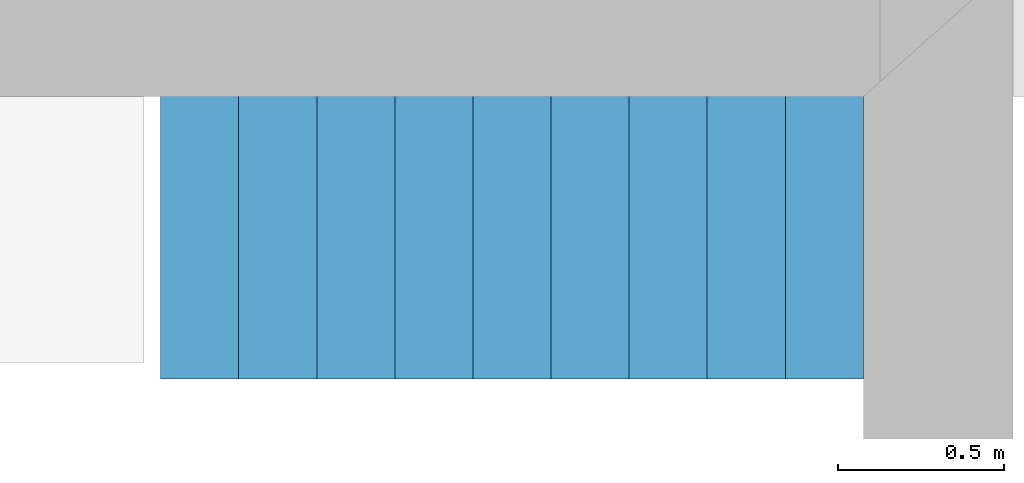
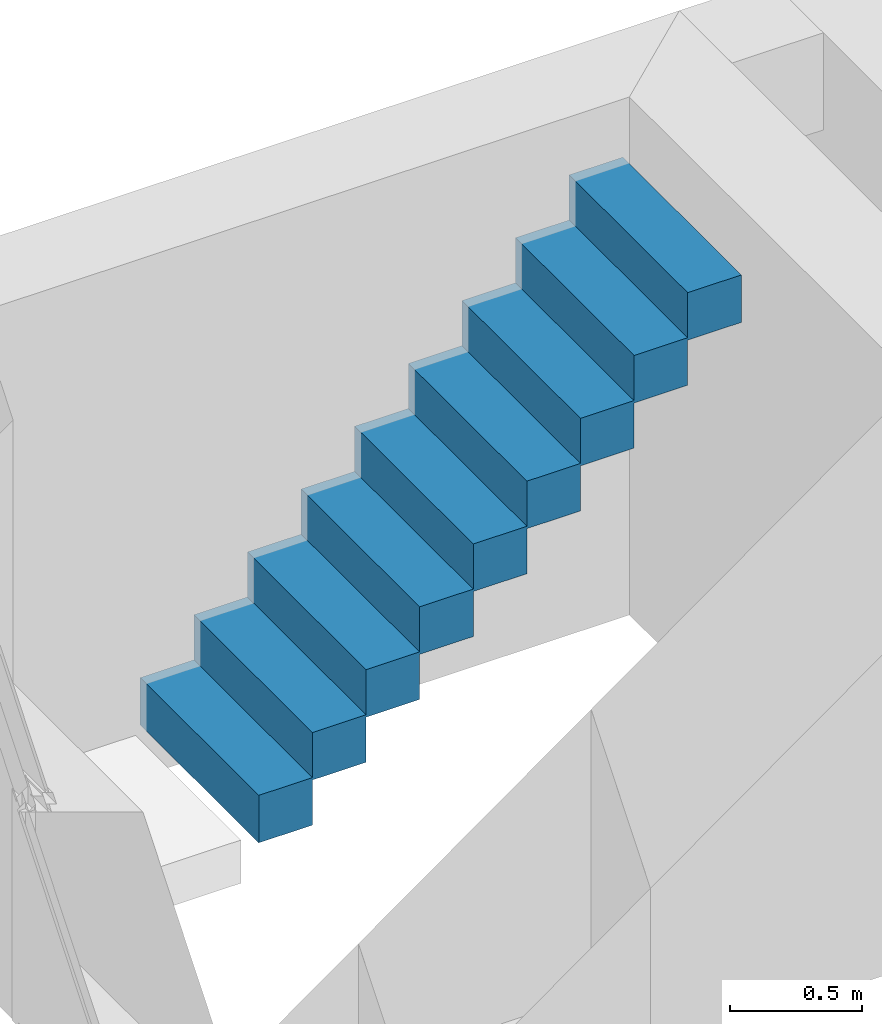
# One storey, part 3 of 3: 1 stair flight.
"""IFC4 building model written with IfcOpenShell, lengths in millimetres."""

from ifc_helpers import new_model, entity, si_unit, converted_unit, frame, origin_with_axes, origin_2d_with_axis, place, context, subcontext, project, spatial, polygons, source, transform, mapped, type_object, type_shapes, element, save


model = new_model("IFC4")

# Units and contexts
model_context = context("Model", 3, precision=1e-05, world=origin_with_axes())
plan_context = context("Plan", 2, precision=1e-05, world=origin_2d_with_axis())
body_context = subcontext(model_context, "Body", "Model", "MODEL_VIEW")
ifc_project = project(units=[si_unit("VOLUMEUNIT", "CUBIC_METRE"), si_unit("LENGTHUNIT", "METRE", prefix="MILLI"), converted_unit("PLANEANGLEUNIT", "degree", entity("IfcReal", 0.0174532925199433), si_unit("PLANEANGLEUNIT", "RADIAN"), dimensions=[0, 0, 0, 0, 0, 0, 0]), si_unit("AREAUNIT", "SQUARE_METRE")], contexts=[model_context, plan_context])

# Site, building, storey
site_placement = place(None, origin_with_axes())
site = spatial("IfcSite", under=ifc_project, at=site_placement)
building_placement = place(site_placement, origin_with_axes())
building = spatial("IfcBuilding", under=site, at=building_placement, Name="Building")
storey_placement = place(building_placement, frame((0.0, 0.0, -2400.00009536743), z_axis=(0.0, 0.0, 1.0), x_axis=(1.0, 0.0, 0.0)))
storey = spatial("IfcBuildingStorey", under=building, at=storey_placement, Name="Basement")

# Stair flight
stair_flight_type = type_object("IfcStairFlightType", Name="STF800", PredefinedType="STRAIGHT")
shared_shape = source(origin_with_axes(), body_context, "Body", "Tessellation", [
    polygons([(0.0, 0.0, -11.1111116409302), (234.999984741211, 0.0, -11.1111116409302), (234.999984741211, 0.0, 208.888900756836), (0.0, 0.0, 208.888900756836), (234.999984741211, 0.0, 197.777786254883), (469.999969482422, 0.0, 197.777786254883), (469.999969482422, 0.0, 417.777801513672), (234.999984741211, 0.0, 417.777801513672), (469.999969482422, 0.0, 406.666687011719), (704.999938964844, 0.0, 406.666687011719), (704.999938964844, 0.0, 626.666687011719), (469.999969482422, 0.0, 626.666687011719), (704.999938964844, 0.0, 615.555541992188), (939.999938964844, 0.0, 615.555541992188), (939.999938964844, 0.0, 835.555603027344), (704.999938964844, 0.0, 835.555603027344), (939.999938964844, 0.0, 824.444458007812), (1174.99987792969, 0.0, 824.444458007812), (1174.99987792969, 0.0, 1044.44445800781), (939.999938964844, 0.0, 1044.44445800781), (1174.99987792969, 0.0, 1033.33337402344), (1409.99987792969, 0.0, 1033.33337402344), (1409.99987792969, 0.0, 1253.33337402344), (1174.99987792969, 0.0, 1253.33337402344), (1409.99987792969, 0.0, 1242.22229003906), (1644.99987792969, 0.0, 1242.22229003906), (1644.99987792969, 0.0, 1462.22229003906), (1409.99987792969, 0.0, 1462.22229003906), (1644.99987792969, 0.0, 1451.11108398438), (1879.99987792969, 0.0, 1451.11108398438), (1879.99987792969, 0.0, 1671.11120605469), (1644.99987792969, 0.0, 1671.11120605469), (1879.99987792969, 0.0, 1660.0), (2115.0, 0.0, 1660.0), (2115.0, 0.0, 1880.0), (1879.99987792969, 0.0, 1880.0), (0.0, 900.0, -11.1111116409302), (0.0, 900.0, 208.888900756836), (234.999984741211, 900.0, 208.888900756836), (234.999984741211, 900.0, -11.1111116409302), (234.999984741211, 900.0, 197.777786254883), (234.999984741211, 900.0, 417.777801513672), (469.999969482422, 900.0, 417.777801513672), (469.999969482422, 900.0, 197.777786254883), (469.999969482422, 900.0, 406.666687011719), (469.999969482422, 900.0, 626.666687011719), (704.999938964844, 900.0, 626.666687011719), (704.999938964844, 900.0, 406.666687011719), (704.999938964844, 900.0, 615.555541992188), (704.999938964844, 900.0, 835.555603027344), (939.999938964844, 900.0, 835.555603027344), (939.999938964844, 900.0, 615.555541992188), (939.999938964844, 900.0, 824.444458007812), (939.999938964844, 900.0, 1044.44445800781), (1174.99987792969, 900.0, 1044.44445800781), (1174.99987792969, 900.0, 824.444458007812), (1174.99987792969, 900.0, 1033.33337402344), (1174.99987792969, 900.0, 1253.33337402344), (1409.99987792969, 900.0, 1253.33337402344), (1409.99987792969, 900.0, 1033.33337402344), (1409.99987792969, 900.0, 1242.22229003906), (1409.99987792969, 900.0, 1462.22229003906), (1644.99987792969, 900.0, 1462.22229003906), (1644.99987792969, 900.0, 1242.22229003906), (1644.99987792969, 900.0, 1451.11108398438), (1644.99987792969, 900.0, 1671.11120605469), (1879.99987792969, 900.0, 1671.11120605469), (1879.99987792969, 900.0, 1451.11108398438), (1879.99987792969, 900.0, 1660.0), (1879.99987792969, 900.0, 1880.0), (2115.0, 900.0, 1880.0), (2115.0, 900.0, 1660.0)], [[[1, 2, 3, 4]], [[5, 6, 7, 8]], [[9, 10, 11, 12]], [[13, 14, 15, 16]], [[17, 18, 19, 20]], [[21, 22, 23, 24]], [[25, 26, 27, 28]], [[29, 30, 31, 32]], [[33, 34, 35, 36]], [[37, 38, 39, 40]], [[41, 42, 43, 44]], [[45, 46, 47, 48]], [[49, 50, 51, 52]], [[53, 54, 55, 56]], [[57, 58, 59, 60]], [[61, 62, 63, 64]], [[65, 66, 67, 68]], [[69, 70, 71, 72]], [[6, 5, 41, 44]], [[29, 32, 66, 65]], [[20, 19, 55, 54]], [[7, 6, 44, 43]], [[34, 33, 69, 72]], [[17, 20, 54, 53]], [[8, 7, 43, 42]], [[35, 34, 72, 71]], [[22, 21, 57, 60]], [[5, 8, 42, 41]], [[36, 35, 71, 70]], [[23, 22, 60, 59]], [[10, 9, 45, 48]], [[33, 36, 70, 69]], [[24, 23, 59, 58]], [[11, 10, 48, 47]], [[21, 24, 58, 57]], [[12, 11, 47, 46]], [[26, 25, 61, 64]], [[9, 12, 46, 45]], [[27, 26, 64, 63]], [[14, 13, 49, 52]], [[28, 27, 63, 62]], [[15, 14, 52, 51]], [[2, 1, 37, 40]], [[25, 28, 62, 61]], [[16, 15, 51, 50]], [[3, 2, 40, 39]], [[30, 29, 65, 68]], [[13, 16, 50, 49]], [[4, 3, 39, 38]], [[31, 30, 68, 67]], [[18, 17, 53, 56]], [[1, 4, 38, 37]], [[32, 31, 67, 66]], [[19, 18, 56, 55]]], closed=True),
])
type_shapes(stair_flight_type, [shared_shape])
stair_flight_placement = place(storey_placement, frame((5664.99996185303, 8899.99961853027, 211.111068725584), z_axis=(0.0, 0.0, 1.0), x_axis=(1.0, 0.0, 0.0)))
element("IfcStairFlight", 1, at=stair_flight_placement, inside=storey, type_object=stair_flight_type, NumberOfRisers=9, NumberOfTreads=8, RiserHeight=208.888900756836, TreadLength=220.000015258789, context=body_context, shape_type="MappedRepresentation", body=[
    mapped(shared_shape, transform((0.0, 0.0, 0.0), x_axis=(1.0, 0.0, 0.0), y_axis=(0.0, 1.0, 0.0), z_axis=(0.0, 0.0, 1.0), scale=1.0)),
])

save(model, "model.ifc")
